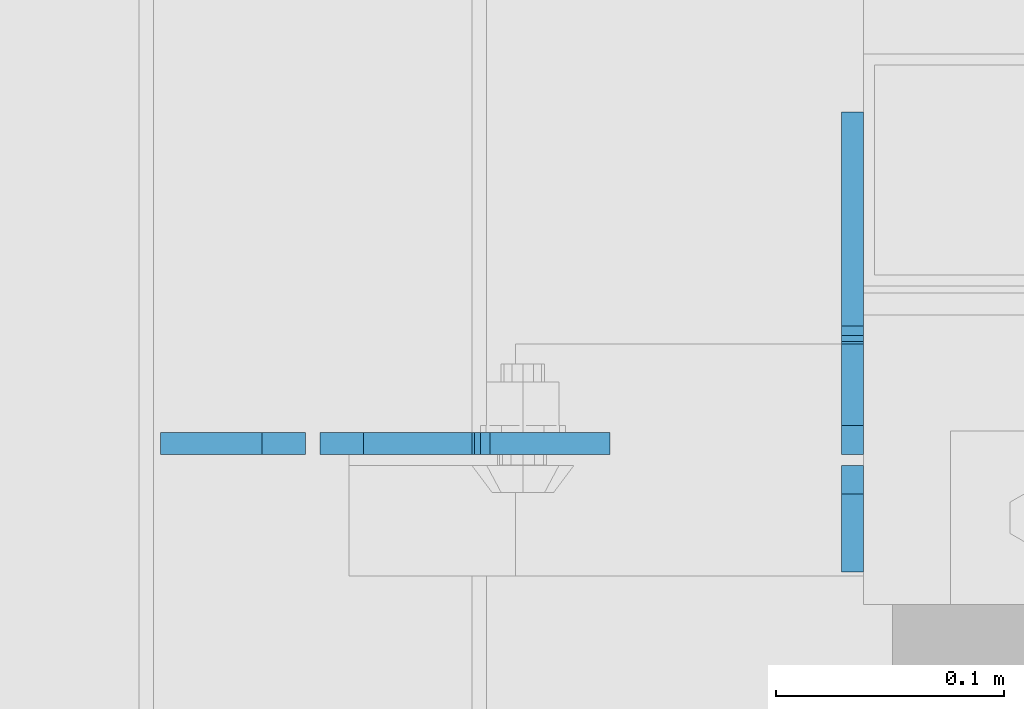
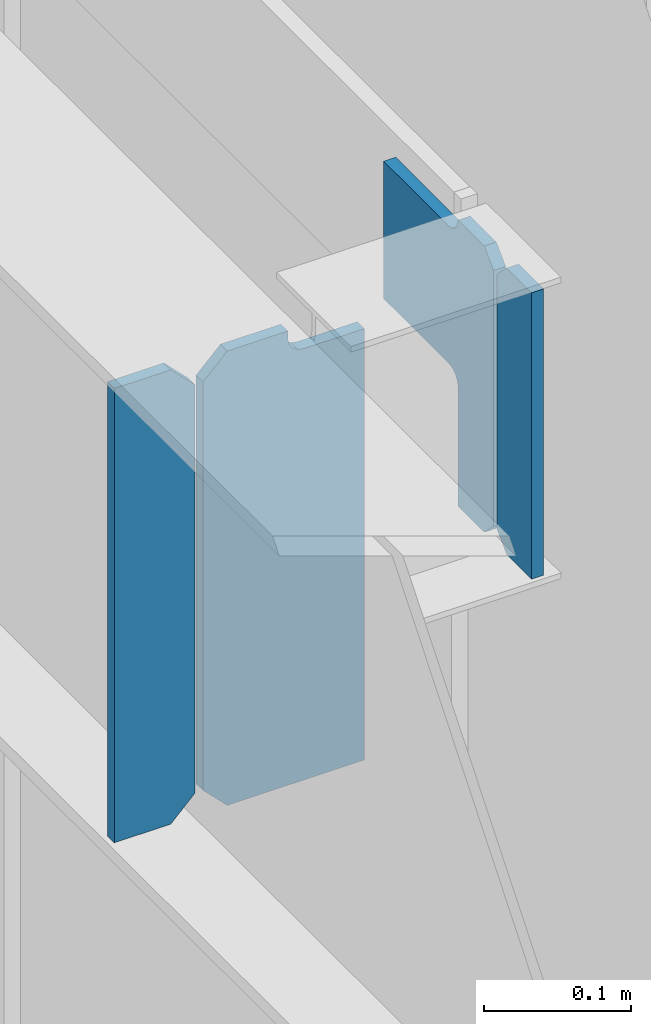
# One storey, part 1103 of 1179: 4 plates, 2 elements without a shape of their own.
"""IFC2X3 building model written with IfcOpenShell, lengths in millimetres."""

from ifc_helpers import new_model, si_unit, frame, origin_with_axes, place, context, subcontext, project, spatial, faceted_brep, material, type_object, element, aggregate, save


model = new_model("IFC2X3")

# Units and contexts
model_context = context("Model", 3, precision=1e-05, world=origin_with_axes())
body_context = subcontext(model_context, "Body", "Model", "MODEL_VIEW")
ifc_project = project(units=[si_unit("LENGTHUNIT", "METRE", prefix="MILLI"), si_unit("AREAUNIT", "SQUARE_METRE"), si_unit("VOLUMEUNIT", "CUBIC_METRE"), si_unit("MASSUNIT", "GRAM", prefix="KILO"), si_unit("TIMEUNIT", "SECOND"), si_unit("PLANEANGLEUNIT", "RADIAN"), si_unit("SOLIDANGLEUNIT", "STERADIAN"), si_unit("THERMODYNAMICTEMPERATUREUNIT", "DEGREE_CELSIUS"), si_unit("LUMINOUSINTENSITYUNIT", "LUMEN")], contexts=[model_context])

# Site, building, storey
site_placement = place(None, origin_with_axes())
site = spatial("IfcSite", under=ifc_project, at=site_placement, CompositionType="ELEMENT")
building_placement = place(site_placement, origin_with_axes())
building = spatial("IfcBuilding", under=site, at=building_placement, Name="Undefined", CompositionType="ELEMENT")
storey_placement = place(building_placement, origin_with_axes())
storey = spatial("IfcBuildingStorey", under=building, at=storey_placement, Name="Undefined", CompositionType="ELEMENT", Elevation=0.0)

# Assembly, plates
assembly_1_placement = place(storey_placement, origin_with_axes())
assembly_1 = element("IfcElementAssembly", 1, at=assembly_1_placement, inside=storey, Name="BEAM", AssemblyPlace="NOTDEFINED", PredefinedType="RIGID_FRAME")
ifc_material = material(Name="STEEL/A36")
plate_type_1 = type_object("IfcPlateType", PredefinedType="NOTDEFINED")
plate_1_placement = place(assembly_1_placement, frame((16462.375, 39986.7442499161, 12728.575), z_axis=(0.0, 0.0, 1.0), x_axis=(1.0, 0.0, 0.0)))
plate_1 = element("IfcPlate", 2, at=plate_1_placement, type_object=plate_type_1, material=ifc_material, Name="PLATE", context=body_context, shape_type="Brep", body=[
    faceted_brep([(66.6749998164378, -4.76249999999709, 377.825), (66.6749999434469, -4.76249999999709, 371.474999553748), (66.6749999434469, 4.76249999999709, 371.474999553748), (66.6749998164378, 4.76249999999709, 377.825), (67.641729938794, -4.76249999999709, 366.614920114053), (67.641729938794, 4.76249999999709, 366.614920114053), (70.394743855788, -4.76249999999709, 362.494743732281), (70.394743855788, 4.76249999999709, 362.494743732281), (74.5149202922948, -4.76249999999709, 359.741729897201), (74.5149202922948, 4.76249999999709, 359.741729897201), (79.3749997512095, -4.76249999999709, 358.774999998475), (79.3749997512095, 4.76249999999709, 358.774999998475), (127.000000004868, -4.76249999999709, 358.774999992755), (127.0, 4.76249999999709, 358.774999992755), (0.0, -4.76249999999709, 358.775000762939), (19.0499992370605, -4.76249999999709, 377.825), (19.0499992370605, 4.76249999999709, 377.825), (0.0, 4.76249999999709, 358.775000762939), (0.0, -4.76250000000073, 19.0499992370605), (0.0, 4.76250000000073, 19.0499992370605), (19.0499992370605, -4.76250000000073, 0.0), (19.0499992370605, 4.76250000000073, 0.0), (127.0, -4.76250000000073, 0.0), (127.0, 4.76250000000073, 0.0)], [[[0, 1, 2, 3]], [[4, 5, 2, 1]], [[6, 7, 5, 4]], [[8, 9, 7, 6]], [[10, 11, 9, 8]], [[12, 13, 11, 10]], [[14, 15, 16, 17]], [[18, 14, 17, 19]], [[20, 18, 19, 21]], [[22, 20, 21, 23]], [[8, 6, 4, 1, 0, 15, 14, 18, 20, 22, 12, 10]], [[16, 15, 0, 3]], [[23, 21, 19, 17, 16, 3, 2, 5, 7, 9, 11, 13]], [[22, 23, 13, 12]]]),
])
plate_type_2 = type_object("IfcPlateType", PredefinedType="NOTDEFINED")
plate_2_placement = place(assembly_1_placement, frame((16456.025, 39986.7442499161, 12728.575), z_axis=(0.0, 0.0, 1.0), x_axis=(-1.0, 0.0, 0.0)))
plate_2 = element("IfcPlate", 3, at=plate_2_placement, type_object=plate_type_2, material=ifc_material, Name="PLATE", context=body_context, shape_type="Brep", body=[
    faceted_brep([(0.0, -4.76250000000073, 19.0499992370605), (0.0, -4.76249999999709, 358.775000762939), (0.0, 4.76249999999709, 358.775000762939), (0.0, 4.76250000000073, 19.0499992370605), (19.0499992370605, -4.76249999999709, 377.825), (19.0499992370605, 4.76249999999709, 377.825), (63.5, -4.76250000000073, 377.825012207031), (63.5, 4.76250000000073, 377.825012207031), (63.5, -4.76250000000073, 0.0), (63.5, 4.76250000000073, 0.0), (19.0499992370605, -4.76250000000073, 0.0), (19.0499992370605, 4.76250000000073, 0.0)], [[[0, 1, 2, 3]], [[1, 4, 5, 2]], [[4, 6, 7, 5]], [[6, 8, 9, 7]], [[8, 10, 11, 9]], [[10, 0, 3, 11]], [[5, 7, 9, 11, 3, 2]], [[10, 8, 6, 4, 1, 0]]]),
])
aggregate(assembly_1, [plate_2, plate_1])

assembly_2_placement = place(storey_placement, origin_with_axes())
assembly_2 = element("IfcElementAssembly", 4, at=assembly_2_placement, inside=storey, Name="BEAM", AssemblyPlace="NOTDEFINED", PredefinedType="RIGID_FRAME")
plate_type_3 = type_object("IfcPlateType", PredefinedType="NOTDEFINED")
plate_3_placement = place(assembly_2_placement, frame((16695.7374969376, 39930.3875, 12874.625), z_axis=(0.0, 0.0, 1.0), x_axis=(0.0, 1.0, 0.0)))
plate_3 = element("IfcPlate", 5, at=plate_3_placement, type_object=plate_type_3, material=ifc_material, Name="PLATE", context=body_context, shape_type="Brep", body=[
    faceted_brep([(0.0, -4.76249999999709, 0.0), (0.0, -4.76250000000073, 238.125), (0.0, 4.76250000000073, 238.125), (0.0, 4.76249999999709, 0.0), (34.1312501907378, -4.76250000000073, 238.125), (34.1312501907378, 4.76250000000073, 238.125), (46.8312500000029, -4.76250000000073, 225.425000190735), (46.8312500000029, 4.76250000000073, 225.425000190735), (46.8312500000029, -4.76250000000073, 12.6999998092651), (46.8312500000029, 4.76250000000073, 12.6999998092651), (34.1312501907378, -4.76250000000073, 0.0), (34.1312501907378, 4.76250000000073, 0.0)], [[[0, 1, 2, 3]], [[1, 4, 5, 2]], [[4, 6, 7, 5]], [[6, 8, 9, 7]], [[8, 10, 11, 9]], [[10, 0, 3, 11]], [[5, 7, 9, 11, 3, 2]], [[10, 8, 6, 4, 1, 0]]]),
])
plate_type_4 = type_object("IfcPlateType", PredefinedType="NOTDEFINED")
plate_4_placement = place(assembly_2_placement, frame((16695.7374968283, 39981.9812517723, 13112.75), z_axis=(0.0, 1.0, 0.0), x_axis=(0.0, 0.0, -1.0)))
plate_4 = element("IfcPlate", 6, at=plate_4_placement, type_object=plate_type_4, material=ifc_material, Name="PLATE", context=body_context, shape_type="Brep", body=[
    faceted_brep([(4.8600797445506, -4.76249999992433, 49.3854800566332), (4.8600797445506, 4.76250000007713, 49.3854798566099), (0.00439653278954211, 4.76250000007713, 48.4187495008009), (0.004396532807732, -4.76249999992433, 48.4187497008243), (8.98025619343389, -4.76249999991705, 52.138493985949), (8.98025619343389, 4.76250000008076, 52.1384937859257), (11.7332700650695, -4.76249999990978, 56.2586704733694), (11.7332700650695, 4.76250000009168, 56.2586702733461), (12.6999999536365, -4.7624999999025, 61.1187499981825), (12.6999999536365, 4.76250000009532, 61.1187497981591), (12.6999993313366, -4.76249999976426, 150.018738193074), (12.6999993313366, 4.7625000002372, 150.018738193059), (12.6999998092651, -4.76249999999527, 1.81898940354586e-12), (0.00115318891766947, -4.7624999999789, 12.6999997569219), (0.00115318891766947, 4.76250000001892, 12.6999997569073), (12.6999998092651, 4.76250000000073, 0.0), (225.425000190735, -4.76250000000073, -6.54836185276508e-11), (225.425000190735, 4.76250000000073, -8.00355337560177e-11), (238.124999073794, -4.7624999999789, 12.6999998091924), (238.124999073794, 4.76250000001892, 12.6999998091778), (238.124996468841, -4.76249999992433, 48.418751110039), (238.124996468841, 4.76250000007713, 48.4187511100245), (139.752749147709, -4.76249999992433, 48.4187504288057), (139.752749147709, 4.76250000007713, 48.4187504287911), (134.893960414411, -4.76249999992433, 49.3849457375982), (134.893960414411, 4.76250000007713, 49.3849457375836), (130.774469166083, -4.76249999991705, 52.1365185940886), (130.774469166083, 4.7625000000844, 52.136518594074), (128.021083799133, -4.76249999990978, 56.254798617425), (128.021083799133, 4.76250000008804, 56.2547986174104), (127.052750480088, -4.7624999999025, 61.1131617072751), (127.052750480088, 4.76250000009895, 61.1131617072606), (127.013628303199, -4.76249999976062, 150.018745226909), (127.013628303199, 4.76250000024083, 150.018745226895)], [[[0, 1, 2, 3]], [[4, 5, 1, 0]], [[6, 7, 5, 4]], [[8, 9, 7, 6]], [[10, 11, 9, 8]], [[12, 13, 14, 15]], [[16, 12, 15, 17]], [[18, 16, 17, 19]], [[20, 18, 19, 21]], [[22, 20, 21, 23]], [[24, 22, 23, 25]], [[26, 24, 25, 27]], [[28, 26, 27, 29]], [[30, 28, 29, 31]], [[32, 30, 31, 33]], [[6, 4, 0, 3, 13, 12, 16, 18, 20, 22, 24, 26, 28, 30, 32, 10, 8]], [[14, 13, 3, 2]], [[33, 31, 29, 27, 25, 23, 21, 19, 17, 15, 14, 2, 1, 5, 7, 9, 11]], [[32, 33, 11, 10]]]),
])
aggregate(assembly_2, [plate_3, plate_4])

save(model, "model.ifc")
